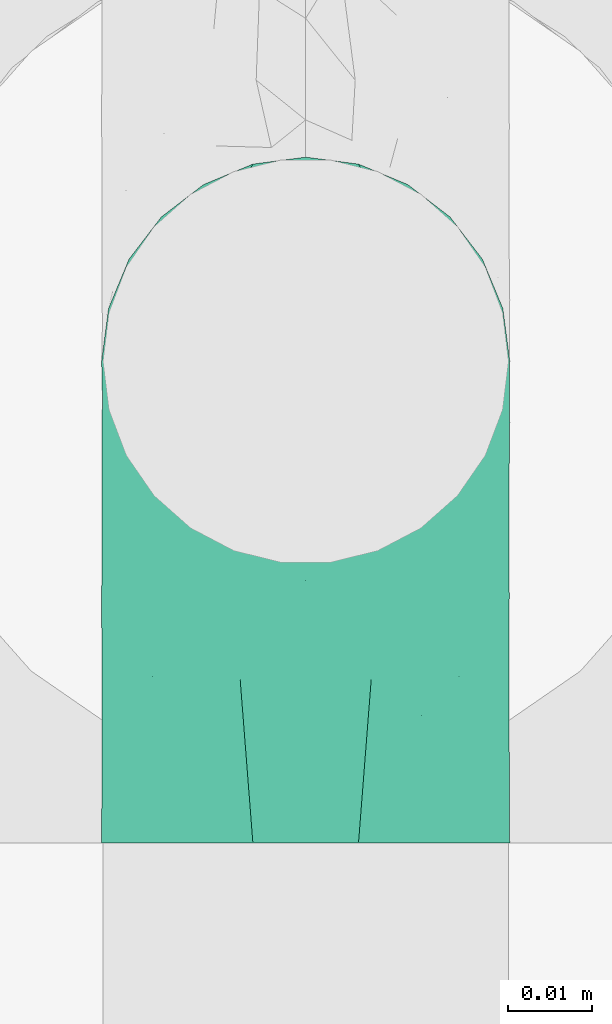
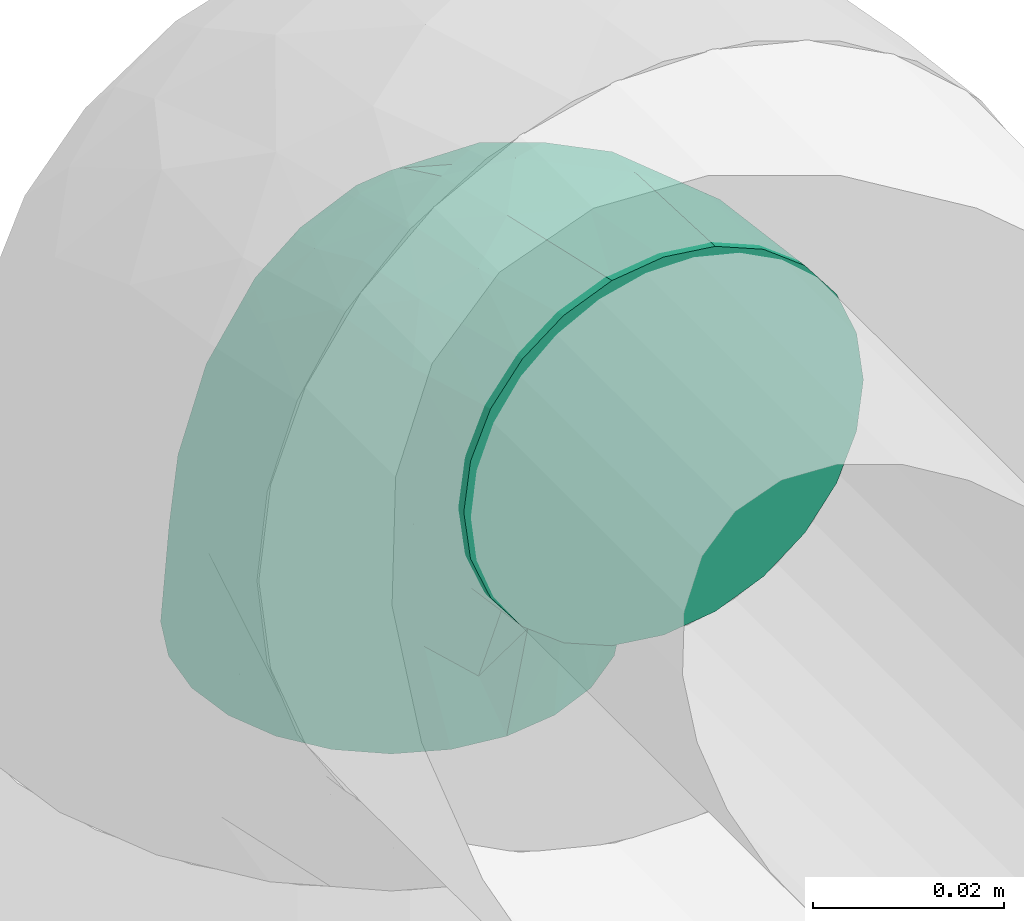
# One storey, part 646 of 827: 1 flow fitting.
"""IFC2X3 building model written with IfcOpenShell, lengths in millimetres."""

from ifc_helpers import new_model, entity, si_unit, converted_unit, derived_unit, direction, frame, origin, place, context, subcontext, project, spatial, faceted_brep, source, transform, mapped, material, type_object, type_shapes, element, save


model = new_model("IFC2X3")

# Units and contexts
model_context = context("Model", 3, precision=0.01, world=origin(), true_north=direction((6.12303176911189e-17, 1.0)))
body_context = subcontext(model_context, "Body", "Model", "MODEL_VIEW")
ifc_project = project(units=[si_unit("LENGTHUNIT", "METRE", prefix="MILLI"), si_unit("AREAUNIT", "SQUARE_METRE"), si_unit("VOLUMEUNIT", "CUBIC_METRE"), converted_unit("PLANEANGLEUNIT", "DEGREE", entity("IfcRatioMeasure", 0.0174532925199433), si_unit("PLANEANGLEUNIT", "RADIAN"), dimensions=[0, 0, 0, 0, 0, 0, 0]), si_unit("MASSUNIT", "GRAM", prefix="KILO"), derived_unit("MASSDENSITYUNIT", [(si_unit("MASSUNIT", "GRAM", prefix="KILO"), 1), (si_unit("LENGTHUNIT", "METRE"), -3)]), derived_unit("MOMENTOFINERTIAUNIT", [(si_unit("LENGTHUNIT", "METRE"), 4)]), si_unit("TIMEUNIT", "SECOND"), si_unit("FREQUENCYUNIT", "HERTZ"), si_unit("THERMODYNAMICTEMPERATUREUNIT", "DEGREE_CELSIUS"), derived_unit("THERMALTRANSMITTANCEUNIT", [(si_unit("MASSUNIT", "GRAM", prefix="KILO"), 1), (si_unit("THERMODYNAMICTEMPERATUREUNIT", "KELVIN"), -1), (si_unit("TIMEUNIT", "SECOND"), -3)]), derived_unit("VOLUMETRICFLOWRATEUNIT", [(si_unit("LENGTHUNIT", "METRE"), 3), (si_unit("TIMEUNIT", "SECOND"), -1)]), derived_unit("MASSFLOWRATEUNIT", [(si_unit("MASSUNIT", "GRAM", prefix="KILO"), 1), (si_unit("TIMEUNIT", "SECOND"), -1)]), derived_unit("ROTATIONALFREQUENCYUNIT", [(si_unit("TIMEUNIT", "SECOND"), -1)]), si_unit("ELECTRICCURRENTUNIT", "AMPERE"), si_unit("ELECTRICVOLTAGEUNIT", "VOLT"), si_unit("POWERUNIT", "WATT"), si_unit("FORCEUNIT", "NEWTON", prefix="KILO"), si_unit("ILLUMINANCEUNIT", "LUX"), si_unit("LUMINOUSFLUXUNIT", "LUMEN"), si_unit("LUMINOUSINTENSITYUNIT", "CANDELA"), derived_unit("USERDEFINED", [(si_unit("MASSUNIT", "GRAM", prefix="KILO"), -1), (si_unit("LENGTHUNIT", "METRE"), -2), (si_unit("TIMEUNIT", "SECOND"), 3), (si_unit("LUMINOUSFLUXUNIT", "LUMEN"), 1)]), derived_unit("LINEARVELOCITYUNIT", [(si_unit("LENGTHUNIT", "METRE"), 1), (si_unit("TIMEUNIT", "SECOND"), -1)]), si_unit("PRESSUREUNIT", "PASCAL"), derived_unit("USERDEFINED", [(si_unit("LENGTHUNIT", "METRE"), -2), (si_unit("MASSUNIT", "GRAM", prefix="KILO"), 1), (si_unit("TIMEUNIT", "SECOND"), -2)]), derived_unit("LINEARFORCEUNIT", [(si_unit("MASSUNIT", "GRAM", prefix="KILO"), 1), (si_unit("LENGTHUNIT", "METRE"), 1), (si_unit("TIMEUNIT", "SECOND"), -2), (si_unit("LENGTHUNIT", "METRE"), -1)]), derived_unit("PLANARFORCEUNIT", [(si_unit("MASSUNIT", "GRAM", prefix="KILO"), 1), (si_unit("LENGTHUNIT", "METRE"), 1), (si_unit("TIMEUNIT", "SECOND"), -2), (si_unit("LENGTHUNIT", "METRE"), -2)])], contexts=[model_context])

# Site, building, storey
site_placement = place(None, origin())
site = spatial("IfcSite", under=ifc_project, at=site_placement, CompositionType="ELEMENT")
building_placement = place(site_placement, origin())
building = spatial("IfcBuilding", under=site, at=building_placement, CompositionType="ELEMENT")
storey_placement = place(building_placement, frame((0.0, 0.0, 28200.0)))
storey = spatial("IfcBuildingStorey", under=building, at=storey_placement, Name="08", CompositionType="ELEMENT", Elevation=28200.0)

# Flow fitting
ifc_material = material()
pipe_fitting_type = type_object("IfcPipeFittingType", Name="ADSK_1", PredefinedType="NOTDEFINED", material=ifc_material)
shared_shape = source(origin(), body_context, "Body", "Brep", [
    faceted_brep([(-57.0, 12.07, -20.91), (-57.0, 6.25, -23.33), (-57.0, 0.0, -24.15), (-57.0, -6.25, -23.33), (-57.0, -12.08, -20.91), (-57.0, -17.08, -17.08), (-57.0, -20.91, -12.08), (-57.0, -23.33, -6.25), (-57.0, -24.15, 0.0), (-57.0, -23.33, 6.25), (-57.0, -20.91, 12.07), (-57.0, -17.08, 17.08), (-57.0, -12.08, 20.91), (-57.0, -6.25, 23.33), (-57.0, 0.0, 24.15), (-57.0, 6.25, 23.33), (-57.0, 12.07, 20.91), (-57.0, 17.08, 17.08), (-57.0, 20.91, 12.07), (-57.0, 23.33, 6.25), (-57.0, 24.15, 0.0), (-57.0, 23.33, -6.25), (-57.0, 20.91, -12.08), (-57.0, 17.08, -17.08), (0.0, 57.0, -24.15), (-6.25, 57.0, -23.33), (-12.07, 57.0, -20.91), (-17.08, 57.0, -17.08), (-20.91, 57.0, -12.08), (-23.33, 57.0, -6.25), (-24.15, 57.0, 0.0), (-23.33, 57.0, 6.25), (-20.91, 57.0, 12.07), (-17.08, 57.0, 17.08), (-12.07, 57.0, 20.91), (-6.25, 57.0, 23.33), (0.0, 57.0, 24.15), (6.25, 57.0, 23.33), (12.08, 57.0, 20.91), (17.08, 57.0, 17.08), (20.91, 57.0, 12.07), (23.33, 57.0, 6.25), (24.15, 57.0, 0.0), (23.33, 57.0, -6.25), (20.91, 57.0, -12.08), (17.08, 57.0, -17.08), (12.08, 57.0, -20.91), (6.25, 57.0, -23.33), (14.9, 21.14, 6.17), (13.61, 24.64, 12.48), (6.23, 8.95, 8.98), (-41.47, -21.06, 0.0), (-41.92, -18.38, 13.72), (-24.64, -13.61, 12.48), (-37.37, -13.24, 18.15), (-6.8, -4.93, 8.18), (-21.76, -15.19, 6.22), (-12.78, -9.18, 0.0), (-37.73, -20.51, 7.75), (-7.38, 7.38, 20.24), (-23.37, -4.26, 20.42), (-11.9, -3.19, 15.86), (-42.14, -8.7, 21.82), (13.24, 37.37, 18.15), (9.33, 23.53, 16.85), (4.26, 23.37, 20.42), (2.77, 10.92, 15.55), (-29.46, 0.91, 23.52), (-44.13, 20.56, 15.69), (-39.25, 26.33, 10.88), (-49.02, 22.92, 9.96), (-34.58, 23.87, 17.15), (-15.8, 6.8, 22.81), (-8.67, 20.47, 23.88), (-18.12, 12.9, 24.08), (-48.29, 14.92, 19.65), (-44.06, -2.85, 23.78), (-9.23, 48.95, 22.58), (-3.78, 42.74, 24.07), (-40.34, 4.26, 24.09), (-44.02, 26.14, 5.46), (-44.04, 9.88, 22.74), (-4.95, 16.87, 22.52), (-2.75, 1.43, 12.5), (-25.48, 40.98, 10.71), (20.51, 37.73, 7.75), (18.38, 41.92, 13.72), (8.7, 42.14, 21.82), (-25.95, -17.97, 0.0), (2.85, 44.06, 23.78), (21.06, 41.47, 0.0), (17.97, 25.95, 0.0), (-24.04, -9.27, 17.13), (-33.26, 33.26, 5.86), (-28.55, 40.57, 0.0), (-40.57, 28.55, 0.0), (-25.29, 47.19, 4.06), (-27.01, 31.1, 16.77), (-15.7, 43.95, 19.9), (-20.27, 45.22, 15.61), (-30.53, 31.98, 12.64), (-11.28, 38.33, 22.92), (-9.97, 27.88, 24.09), (-20.15, 30.26, 21.25), (-31.25, 11.75, 23.64), (-28.75, 7.23, 24.15), (-29.53, 18.06, 22.27), (-28.44, 24.21, 20.02), (-37.55, 17.7, 20.26), (-15.88, 29.25, 22.99), (-20.82, 20.82, 23.44), (-0.91, 29.46, 23.52), (-13.5, -7.67, 12.04), (1.49, 1.56, 5.16), (8.86, 10.35, 4.59), (0.38, -0.38, 0.0), (9.18, 12.78, 0.0), (-37.37, -13.24, -18.15), (8.86, 10.35, -4.59), (-45.22, 20.27, -15.61), (-43.95, 15.7, -19.9), (-38.33, 11.28, -22.92), (-48.95, 9.23, -22.58), (-47.19, 25.29, -4.06), (-33.26, 33.26, -5.86), (18.38, 41.92, -13.72), (-30.26, 20.15, -21.25), (2.85, 44.06, -23.78), (-4.26, 40.34, -24.09), (-40.98, 25.48, -10.71), (-41.92, -18.38, -13.72), (9.25, 23.5, -16.92), (4.26, 23.37, -20.42), (13.24, 37.37, -18.15), (-37.73, -20.51, -7.75), (-11.75, 31.25, -23.64), (-7.23, 28.75, -24.15), (-12.9, 18.12, -24.08), (8.7, 42.14, -21.82), (-44.06, -2.85, -23.78), (-6.8, 15.8, -22.81), (-20.47, 8.67, -23.88), (-24.64, -13.61, -12.48), (-42.74, 3.78, -24.07), (-18.06, 29.53, -22.27), (-24.21, 28.44, -20.02), (-27.88, 9.97, -24.09), (-31.1, 27.01, -16.77), (-26.14, 44.02, -5.46), (14.9, 21.14, -6.17), (20.51, 37.73, -7.75), (-9.88, 44.04, -22.74), (-20.56, 44.13, -15.69), (-21.76, -15.19, -6.22), (-13.5, -7.67, -12.04), (-24.14, -9.76, -16.74), (-11.9, -3.19, -15.86), (-14.92, 48.29, -19.65), (-23.37, -4.26, -20.42), (-0.91, 29.46, -23.52), (-26.33, 39.25, -10.88), (-23.87, 34.58, -17.15), (-42.14, -8.7, -21.82), (-22.92, 49.02, -9.96), (13.61, 24.64, -12.48), (-31.98, 30.53, -12.64), (-16.87, 4.95, -22.52), (-17.7, 37.55, -20.26), (-29.25, 15.88, -22.99), (-20.82, 20.82, -23.44), (-29.46, 0.91, -23.52), (-7.38, 7.38, -20.24), (2.77, 10.92, -15.55), (6.23, 8.95, -8.98), (-6.8, -4.93, -8.18), (-2.81, 1.41, -12.54), (1.49, 1.56, -5.16)], [[[0, 1, 2, 3, 4, 5, 6, 7, 8, 9, 10, 11, 12, 13, 14, 15, 16, 17, 18, 19, 20, 21, 22, 23]], [[24, 25, 26, 27, 28, 29, 30, 31, 32, 33, 34, 35, 36, 37, 38, 39, 40, 41, 42, 43, 44, 45, 46, 47]], [[48, 49, 50]], [[9, 8, 51]], [[52, 53, 54]], [[55, 56, 57]], [[10, 58, 52]], [[9, 58, 10]], [[59, 60, 61]], [[54, 12, 11]], [[54, 62, 12]], [[63, 39, 38]], [[64, 65, 66]], [[62, 60, 67]], [[68, 69, 70]], [[71, 69, 68]], [[72, 73, 74]], [[16, 75, 17]], [[13, 76, 14]], [[35, 77, 78]], [[14, 79, 15]], [[17, 68, 18]], [[14, 76, 79]], [[20, 19, 80]], [[70, 19, 18]], [[81, 15, 79]], [[15, 81, 16]], [[73, 72, 82]], [[66, 83, 50]], [[32, 31, 84]], [[85, 86, 49]], [[63, 87, 65]], [[56, 58, 88]], [[36, 89, 37]], [[85, 41, 40]], [[36, 35, 78]], [[90, 41, 85]], [[40, 39, 86]], [[12, 62, 13]], [[86, 85, 40]], [[48, 85, 49]], [[85, 91, 90]], [[87, 38, 37]], [[92, 60, 54]], [[80, 69, 93]], [[93, 94, 95]], [[10, 52, 11]], [[94, 96, 30]], [[97, 98, 99]], [[80, 93, 95]], [[100, 97, 84]], [[99, 98, 33]], [[101, 102, 78]], [[103, 101, 98]], [[96, 31, 30]], [[77, 98, 101]], [[77, 35, 34]], [[34, 33, 98]], [[9, 51, 58]], [[87, 63, 38]], [[104, 105, 74]], [[106, 103, 107]], [[106, 81, 104]], [[75, 68, 17]], [[108, 107, 71]], [[33, 32, 99]], [[109, 103, 110]], [[101, 109, 102]], [[89, 78, 111]], [[53, 52, 58]], [[54, 11, 52]], [[60, 62, 54]], [[88, 58, 51]], [[76, 62, 67]], [[53, 112, 92]], [[60, 59, 72]], [[39, 63, 86]], [[49, 86, 63]], [[89, 87, 37]], [[42, 41, 90]], [[111, 82, 65]], [[111, 65, 87]], [[65, 59, 66]], [[104, 81, 79]], [[75, 81, 108]], [[32, 84, 99]], [[97, 99, 84]], [[98, 97, 103]], [[106, 107, 108]], [[74, 102, 110]], [[111, 78, 102]], [[74, 110, 104]], [[74, 67, 72]], [[61, 92, 112]], [[66, 59, 61]], [[56, 53, 58]], [[66, 50, 49]], [[61, 112, 83]], [[66, 49, 64]], [[78, 89, 36]], [[87, 89, 111]], [[62, 76, 13]], [[79, 76, 67]], [[100, 93, 69]], [[96, 93, 84]], [[55, 113, 50]], [[113, 114, 50]], [[104, 79, 105]], [[106, 104, 110]], [[20, 80, 95]], [[85, 48, 91]], [[115, 114, 113]], [[116, 91, 48]], [[70, 80, 19]], [[93, 96, 94]], [[84, 31, 96]], [[103, 106, 110]], [[81, 106, 108]], [[103, 97, 107]], [[71, 107, 97]], [[71, 97, 100]], [[108, 71, 68]], [[79, 67, 105]], [[67, 74, 105]], [[115, 113, 57]], [[112, 56, 55]], [[56, 88, 57]], [[60, 72, 67]], [[82, 72, 59]], [[65, 82, 59]], [[82, 111, 73]], [[111, 102, 73]], [[102, 74, 73]], [[81, 75, 16]], [[68, 75, 108]], [[68, 70, 18]], [[80, 70, 69]], [[98, 77, 34]], [[78, 77, 101]], [[93, 100, 84]], [[71, 100, 69]], [[102, 109, 110]], [[101, 103, 109]], [[53, 92, 54]], [[61, 60, 92]], [[56, 112, 53]], [[83, 112, 55]], [[50, 83, 55]], [[61, 83, 66]], [[49, 63, 64]], [[65, 64, 63]], [[57, 113, 55]], [[114, 115, 116]], [[116, 48, 114]], [[48, 50, 114]], [[117, 5, 4]], [[116, 115, 118]], [[119, 120, 23]], [[121, 122, 120]], [[95, 123, 20]], [[0, 23, 120]], [[124, 95, 94]], [[125, 45, 44]], [[121, 120, 126]], [[24, 127, 128]], [[22, 21, 129]], [[0, 122, 1]], [[5, 117, 130]], [[131, 132, 133]], [[134, 88, 51]], [[135, 136, 137]], [[6, 5, 130]], [[46, 138, 47]], [[139, 3, 2]], [[140, 141, 137]], [[6, 134, 7]], [[134, 130, 142]], [[143, 2, 1]], [[144, 126, 145]], [[121, 146, 143]], [[147, 120, 119]], [[94, 148, 124]], [[149, 150, 91]], [[30, 29, 148]], [[151, 25, 128]], [[27, 152, 28]], [[134, 153, 88]], [[154, 155, 156]], [[27, 26, 157]], [[151, 26, 25]], [[155, 158, 156]], [[24, 47, 127]], [[1, 122, 143]], [[138, 132, 159]], [[160, 152, 161]], [[24, 128, 25]], [[46, 133, 138]], [[162, 117, 4]], [[148, 160, 124]], [[152, 160, 163]], [[154, 142, 155]], [[45, 125, 133]], [[133, 46, 45]], [[125, 164, 133]], [[51, 7, 134]], [[42, 90, 43]], [[165, 147, 129]], [[153, 134, 142]], [[43, 150, 44]], [[162, 4, 3]], [[141, 140, 166]], [[117, 162, 158]], [[163, 29, 28]], [[43, 90, 150]], [[123, 21, 20]], [[144, 151, 135]], [[157, 152, 27]], [[167, 145, 161]], [[23, 22, 119]], [[168, 126, 169]], [[121, 168, 146]], [[139, 143, 170]], [[142, 130, 117]], [[8, 7, 51]], [[134, 6, 130]], [[139, 162, 3]], [[170, 166, 158]], [[170, 158, 162]], [[158, 171, 156]], [[44, 150, 125]], [[91, 150, 90]], [[164, 125, 150]], [[132, 138, 133]], [[127, 138, 159]], [[131, 164, 172]], [[132, 171, 140]], [[135, 151, 128]], [[157, 151, 167]], [[22, 129, 119]], [[147, 119, 129]], [[120, 147, 126]], [[144, 145, 167]], [[137, 146, 169]], [[170, 143, 146]], [[137, 169, 135]], [[137, 159, 140]], [[171, 172, 156]], [[173, 174, 175]], [[156, 175, 154]], [[174, 57, 153]], [[132, 172, 171]], [[172, 164, 173]], [[143, 139, 2]], [[162, 139, 170]], [[138, 127, 47]], [[128, 127, 159]], [[165, 124, 160]], [[123, 124, 129]], [[149, 173, 164]], [[176, 174, 173]], [[135, 128, 136]], [[144, 135, 169]], [[150, 149, 164]], [[176, 118, 115]], [[149, 91, 116]], [[30, 148, 94]], [[163, 148, 29]], [[124, 123, 95]], [[129, 21, 123]], [[126, 144, 169]], [[151, 144, 167]], [[126, 147, 145]], [[161, 145, 147]], [[161, 147, 165]], [[167, 161, 152]], [[128, 159, 136]], [[159, 137, 136]], [[154, 153, 142]], [[132, 140, 159]], [[174, 176, 57]], [[57, 88, 153]], [[166, 140, 171]], [[158, 166, 171]], [[166, 170, 141]], [[170, 146, 141]], [[146, 137, 141]], [[151, 157, 26]], [[152, 157, 167]], [[152, 163, 28]], [[148, 163, 160]], [[120, 122, 0]], [[143, 122, 121]], [[124, 165, 129]], [[161, 165, 160]], [[146, 168, 169]], [[121, 126, 168]], [[142, 117, 155]], [[158, 155, 117]], [[175, 156, 172]], [[153, 154, 174]], [[173, 175, 172]], [[174, 154, 175]], [[164, 131, 133]], [[172, 132, 131]], [[176, 173, 118]], [[57, 176, 115]], [[173, 149, 118]], [[149, 116, 118]]]),
])
type_shapes(pipe_fitting_type, [shared_shape])
flow_fitting_placement = place(storey_placement, frame((36629.64, 16255.49, 3550.0), z_axis=(1.0, 0.0, 0.0), x_axis=(0.0, 0.0, 1.0)))
element("IfcFlowFitting", 1, at=flow_fitting_placement, inside=storey, type_object=pipe_fitting_type, material=ifc_material, Name="ADSK_1", ObjectType="ADSK_1", context=body_context, shape_type="MappedRepresentation", body=[
    mapped(shared_shape, transform((0.0, 0.0, 0.0), scale=1.0)),
])

save(model, "model.ifc")
